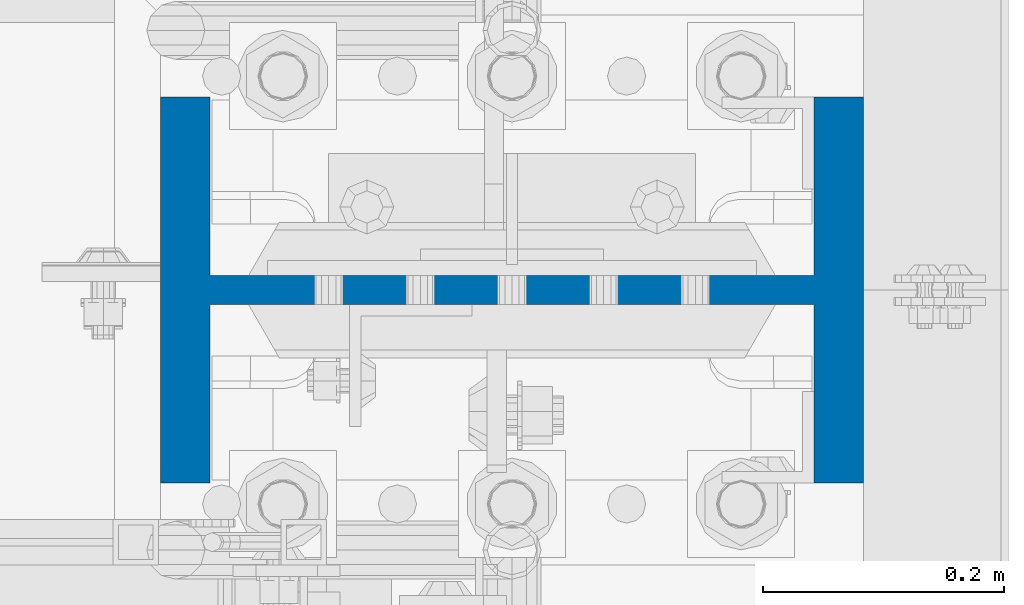
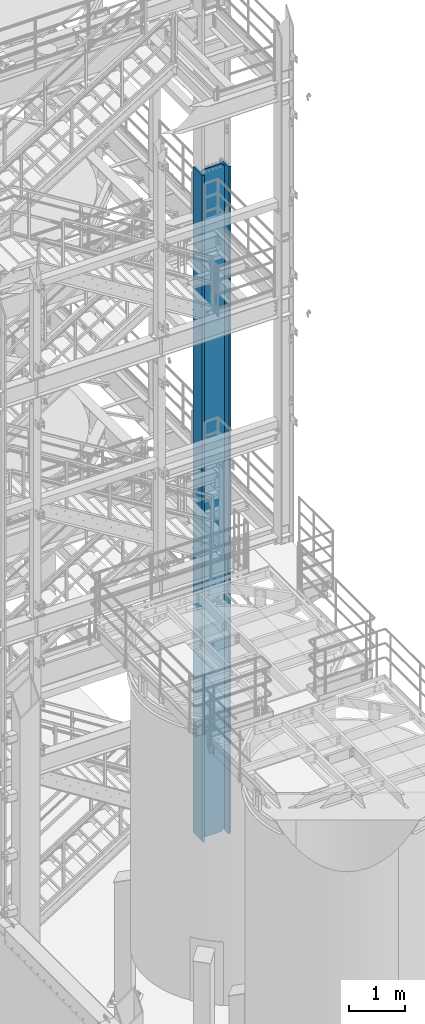
# One storey, part 668 of 1876: 1 column, 1 element without a shape of its own.
"""IFC2X3 building model written with IfcOpenShell, lengths in millimetres."""

from ifc_helpers import new_model, si_unit, frame, origin_with_axes, place, context, subcontext, project, spatial, faceted_brep, material, type_object, element, aggregate, save


model = new_model("IFC2X3")

# Units and contexts
model_context = context("Model", 3, precision=1e-05, world=origin_with_axes())
body_context = subcontext(model_context, "Body", "Model", "MODEL_VIEW")
ifc_project = project(units=[si_unit("LENGTHUNIT", "METRE", prefix="MILLI"), si_unit("AREAUNIT", "SQUARE_METRE"), si_unit("VOLUMEUNIT", "CUBIC_METRE"), si_unit("MASSUNIT", "GRAM", prefix="KILO"), si_unit("TIMEUNIT", "SECOND"), si_unit("PLANEANGLEUNIT", "RADIAN"), si_unit("SOLIDANGLEUNIT", "STERADIAN"), si_unit("THERMODYNAMICTEMPERATUREUNIT", "DEGREE_CELSIUS"), si_unit("LUMINOUSINTENSITYUNIT", "LUMEN")], contexts=[model_context])

# Site, building, storey
site_placement = place(None, origin_with_axes())
site = spatial("IfcSite", under=ifc_project, at=site_placement, CompositionType="ELEMENT")
building_placement = place(site_placement, origin_with_axes())
building = spatial("IfcBuilding", under=site, at=building_placement, Name="Undefined", CompositionType="ELEMENT")
storey_placement = place(building_placement, origin_with_axes())
storey = spatial("IfcBuildingStorey", under=building, at=storey_placement, Name="Undefined", CompositionType="ELEMENT", Elevation=0.0)

# Assembly, column
assembly_placement = place(storey_placement, origin_with_axes())
assembly = element("IfcElementAssembly", 1, at=assembly_placement, inside=storey, Name="COLUMN", AssemblyPlace="NOTDEFINED", PredefinedType="RIGID_FRAME")
ifc_material = material(Name="STEEL/A992")
column_type = type_object("IfcColumnType", Name="W21X201", PredefinedType="NOTDEFINED")
column_placement = place(assembly_placement, frame((7620.0, -4572.0, 0.0), z_axis=(-1.0, 0.0, 0.0), x_axis=(0.0, 0.0, 1.0)))
column = element("IfcColumn", 2, at=column_placement, type_object=column_type, material=ifc_material, Name="COLUMN", ObjectType="W21X201", context=body_context, shape_type="Brep", body=[
    faceted_brep([(112.712499999999, 11.90625, 200.025000762939), (112.712499999999, 11.90625, -200.025000762939), (88.9, -11.90625, -200.025000762939), (88.9, -11.90625, 200.025000762939), (14528.8, -160.3375, 292.1), (14528.8, 160.3375, 292.1), (130.174999999997, 160.3375, 292.1), (130.175, -160.3375, 292.099999999999), (139.700000000013, -160.3375, 250.825), (14478.0, -160.3375, 250.825), (14528.8, -160.3375, 250.825), (88.9, -160.3375, 250.825), (139.700000000013, -11.90625, 250.825), (14478.0, -11.90625, 250.825), (14528.8, -11.90625, 250.825), (88.9, -11.90625, 250.825), (14528.8, -160.3375, -292.1), (14528.8, -160.3375, -250.825), (14478.0000007629, -160.3375, -250.825), (139.700000000013, -160.3375, -250.825), (88.9, -160.3375, -250.825), (130.175000825646, -160.3375, -292.100000825653), (14528.8, 160.3375, -292.1), (130.175000825646, 160.3375, -292.1), (139.700000000013, 160.3375, -250.825), (14478.0000007629, 160.3375, -250.825), (14528.8, 160.3375, -250.825), (88.9, 160.3375, -250.825), (14528.8, 11.90625, -250.825), (14528.8, -11.90625, -250.825), (14478.0000007629, -11.90625, -250.825), (139.700000000013, -11.90625, -250.825), (88.9, -11.90625, -250.825), (114.300000381483, -11.90625, -200.025000762939), (114.300000381483, 11.90625, -200.025000762939), (124.020159417574, 11.90625, -201.958460608115), (124.020159417574, -11.90625, -201.958460608115), (132.260512353882, 11.90625, -207.464488409071), (132.260512353882, -11.90625, -207.464488409071), (137.766540154838, 11.90625, -215.704841345379), (137.766540154838, -11.90625, -215.704841345379), (139.700000000013, 11.90625, -225.42500038147), (139.700000000013, -11.90625, -225.42500038147), (139.700000000013, 11.90625, -250.825), (88.9, 11.90625, -250.825), (14478.0000007629, 11.90625, -250.825), (14481.8669204533, 11.90625, -231.384681927819), (14481.8669204533, -11.90625, -231.384681927819), (14492.8789760552, 11.90625, -214.903976055204), (14492.8789760552, -11.90625, -214.903976055204), (14509.3596819278, 11.90625, -203.891920453291), (14509.3596819278, -11.90625, -203.891920453291), (14528.8, -11.90625, -200.02500076294), (14528.8, 11.90625, -200.02500076294), (14528.8, 11.90625, 200.02500076294), (14528.8, -11.90625, 200.02500076294), (14509.3596811649, 11.90625, 203.891920453291), (14509.3596811649, -11.90625, 203.891920453291), (14492.8789752923, 11.90625, 214.903976055204), (14492.8789752923, -11.90625, 214.903976055204), (14481.8669196904, 11.90625, 231.384681927819), (14481.8669196904, -11.90625, 231.384681927819), (14478.0, 11.90625, 250.825), (14528.8, 11.90625, 250.825), (14528.8, 160.3375, 250.825), (14478.0, 160.3375, 250.825), (139.700000000013, 160.3375, 250.825), (88.9, 160.3375, 250.825), (88.9, 11.90625, 250.825), (139.700000000013, 11.90625, 250.825), (139.700000000013, 11.90625, 225.42500038147), (139.700000000013, -11.90625, 225.42500038147), (137.766540154838, 11.90625, 215.704841345379), (137.766540154838, -11.90625, 215.704841345379), (132.260512353882, 11.90625, 207.464488409071), (132.260512353882, -11.90625, 207.464488409071), (124.020159417574, 11.90625, 201.958460608115), (124.020159417574, -11.90625, 201.958460608115), (114.300000381483, 11.90625, 200.025000762939), (114.300000381483, -11.90625, 200.025000762939)], [[[0, 1, 2, 3]], [[4, 5, 6, 7]], [[8, 9, 10, 4, 7, 11]], [[12, 13, 14, 10, 9, 8, 11, 15]], [[16, 17, 18, 19, 20, 21]], [[22, 16, 21, 23]], [[24, 25, 26, 22, 23, 27]], [[17, 16, 22, 26, 28, 29]], [[19, 18, 17, 29, 30, 31, 32, 20]], [[33, 34, 35, 36]], [[36, 35, 37, 38]], [[38, 37, 39, 40]], [[40, 39, 41, 42]], [[42, 41, 43, 31]], [[31, 43, 44, 32]], [[27, 23, 21, 20, 32, 44]], [[43, 45, 28, 26, 25, 24, 27, 44]], [[29, 28, 45, 30]], [[30, 45, 46, 47]], [[47, 46, 48, 49]], [[49, 48, 50, 51]], [[52, 51, 50, 53]], [[54, 55, 52, 53]], [[55, 54, 56, 57]], [[57, 56, 58, 59]], [[59, 58, 60, 61]], [[61, 60, 62, 13]], [[14, 13, 62, 63]], [[64, 5, 4, 10, 14, 63]], [[5, 64, 65, 66, 67, 6]], [[11, 7, 6, 67, 68, 15]], [[66, 65, 64, 63, 62, 69, 68, 67]], [[15, 68, 69, 12]], [[12, 69, 70, 71]], [[71, 70, 72, 73]], [[73, 72, 74, 75]], [[75, 74, 76, 77]], [[77, 76, 78, 79]], [[79, 78, 0, 3]], [[33, 36, 38, 40, 42, 31, 30, 47, 49, 51, 52, 55, 57, 59, 61, 13, 12, 71, 73, 75, 77, 79, 3, 2]], [[34, 33, 2, 1]], [[78, 76, 74, 72, 70, 69, 62, 60, 58, 56, 54, 53, 50, 48, 46, 45, 43, 41, 39, 37, 35, 34, 1, 0]]]),
])
aggregate(assembly, [column])

save(model, "model.ifc")
